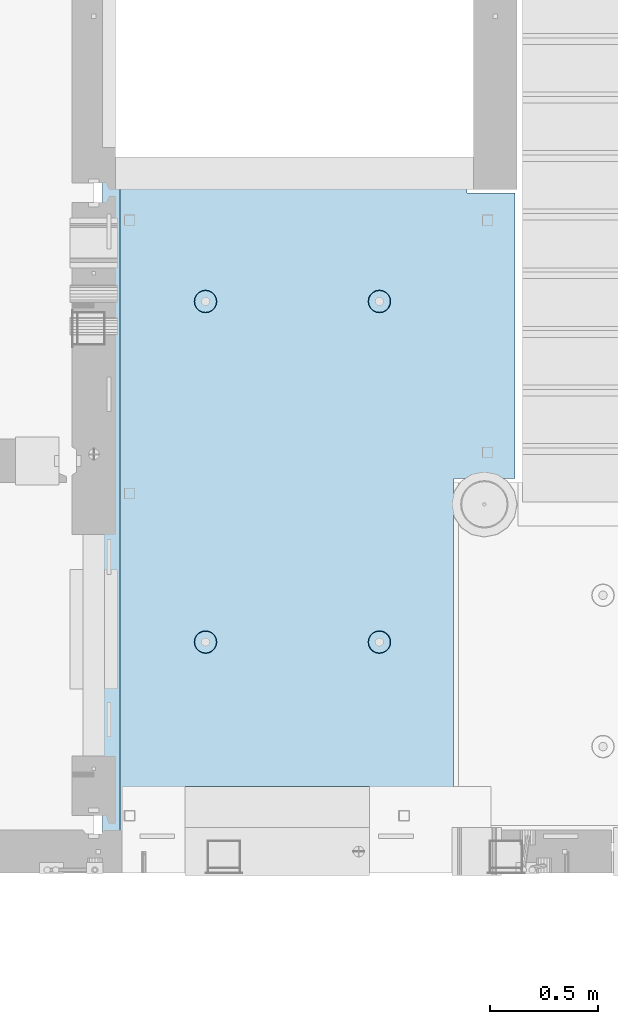
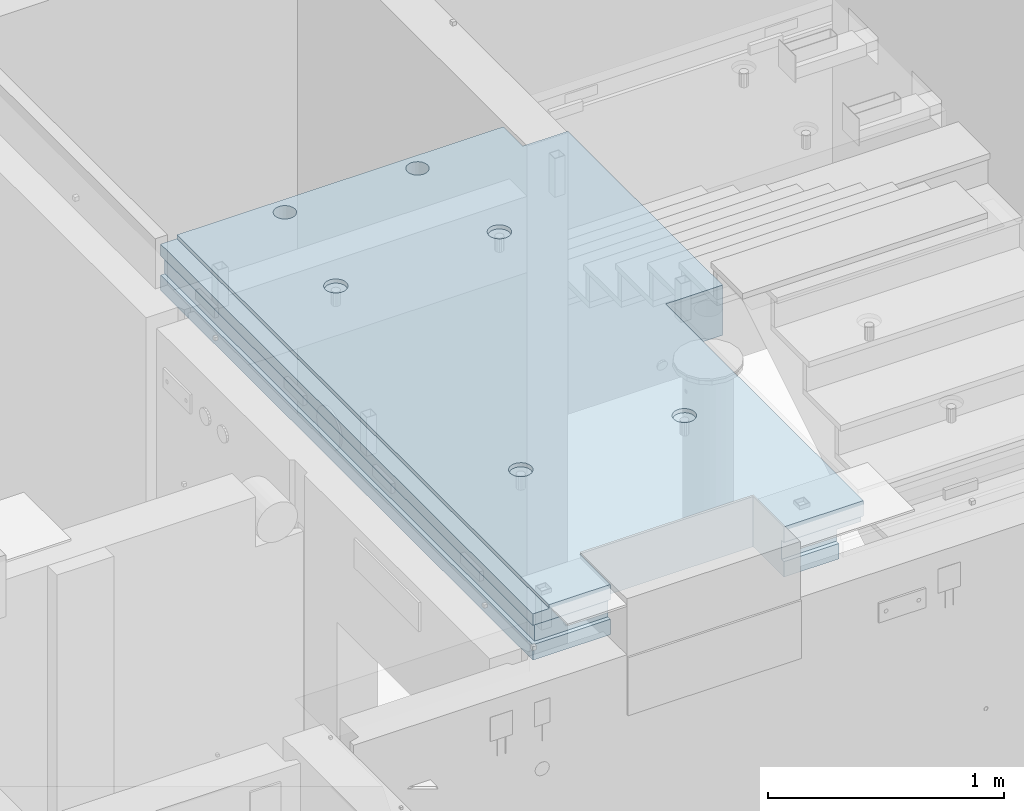
# One storey, part 148 of 264: 1 slab, 1 element without a shape of its own.
"""IFC2X3 building model written with IfcOpenShell, lengths in millimetres."""

import ifcopenshell
import ifcopenshell.guid

model = None  # the IFC model being written
_history = None  # IfcOwnerHistory: only IFC2X3 demands one
_inside = {}  # id of a spatial element -> (the spatial element, [elements in it])
_under = {}  # id of a project, library or spatial element -> (it, [spatial elements below it])
_declared = {}  # id of a project -> (the project, [libraries it declares])
_typed = {}  # id of a type object -> (the type object, [elements of that type])
_made_of = {}  # id of a material, layer set ... -> (it, [elements and type objects made of it])


def new_model(schema):
    """Start an empty IFC model of exactly this schema.

    Asked for "IFC4X3", IfcOpenShell would pick the latest addendum, in which some entities
    have other attributes; the version numbers below select the first issue.
    IFC2X3 requires an IfcOwnerHistory on every rooted entity: one is made here for all.
    """
    global model, _history
    if schema == "IFC4X3":
        model = ifcopenshell.file(schema_version=(4, 3, 0, 0))
    else:
        model = ifcopenshell.file(schema=schema)
    _inside.clear()
    _under.clear()
    _declared.clear()
    _typed.clear()
    _made_of.clear()
    _history = None
    if model.schema == "IFC2X3":
        org = make("IfcOrganization", Name="unknown")
        user = make(
            "IfcPersonAndOrganization",
            ThePerson=make("IfcPerson", FamilyName="unknown"),
            TheOrganization=org,
        )
        app = make(
            "IfcApplication",
            ApplicationDeveloper=org,
            Version="unknown",
            ApplicationFullName="unknown",
            ApplicationIdentifier="unknown",
        )
        _history = make(
            "IfcOwnerHistory",
            OwningUser=user,
            OwningApplication=app,
            ChangeAction="ADDED",
            CreationDate=0,
        )
    return model


def make(cls, **values):
    """One entity of the class cls with the attributes given. An attribute that is None is left unset."""
    return model.create_entity(
        cls, **{name: value for name, value in values.items() if value is not None}
    )


def rooted(cls, **values):
    """An entity with a GlobalId (a new one), such as an element, a storey or a relation."""
    return make(cls, GlobalId=ifcopenshell.guid.new(), OwnerHistory=_history, **values)


def si_unit(unit_type, name, prefix=None):
    """IfcSIUnit, for example si_unit("LENGTHUNIT", "METRE", prefix="MILLI")."""
    return make("IfcSIUnit", UnitType=unit_type, Prefix=prefix, Name=name)


def assignment(units):
    """IfcUnitAssignment: the units of a project."""
    return None if units is None else make("IfcUnitAssignment", Units=units)


def point(xyz):
    """IfcCartesianPoint."""
    return None if xyz is None else make("IfcCartesianPoint", Coordinates=xyz)


def direction(xyz):
    """IfcDirection."""
    return None if xyz is None else make("IfcDirection", DirectionRatios=xyz)


def frame(location, z_axis=None, x_axis=None):
    """IfcAxis2Placement3D, a coordinate frame: its origin and axes. An axis left out is left unset."""
    return make(
        "IfcAxis2Placement3D",
        Location=point(location),
        Axis=direction(z_axis),
        RefDirection=direction(x_axis),
    )


def origin_with_axes():
    """The frame at (0, 0, 0) with the z axis (0, 0, 1) and the x axis (1, 0, 0) written out."""
    return frame((0.0, 0.0, 0.0), z_axis=(0.0, 0.0, 1.0), x_axis=(1.0, 0.0, 0.0))


def place(relative_to, where):
    """IfcLocalPlacement: puts the frame where relative to a parent placement (None: the world)."""
    return make(
        "IfcLocalPlacement", PlacementRelTo=relative_to, RelativePlacement=where
    )


def context(
    kind, dimensions, precision=None, world=None, true_north=None, identifier=None
):
    """IfcGeometricRepresentationContext, for example the 3D "Model" context."""
    return make(
        "IfcGeometricRepresentationContext",
        ContextIdentifier=identifier,
        ContextType=kind,
        CoordinateSpaceDimension=dimensions,
        Precision=precision,
        WorldCoordinateSystem=world,
        TrueNorth=true_north,
    )


def subcontext(parent, identifier, kind, view, scale=None):
    """IfcGeometricRepresentationSubContext, for example "Body" below "Model"."""
    return make(
        "IfcGeometricRepresentationSubContext",
        ContextIdentifier=identifier,
        ContextType=kind,
        ParentContext=parent,
        TargetScale=scale,
        TargetView=view,
    )


def project(units=None, contexts=None):
    """IfcProject with its units and contexts."""
    return rooted(
        "IfcProject",
        Name="project",
        RepresentationContexts=contexts,
        UnitsInContext=assignment(units),
    )


def spatial(cls, under=None, at=None, **own):
    """A site, building, storey or space (cls), placed at a placement, below another one or the project."""
    s = rooted(cls, ObjectPlacement=at, **own)
    if under is not None:
        _under.setdefault(under.id(), (under, []))[1].append(s)
    return s


def faces_of(points, faces, orient=None, outer=None):
    """IfcFace entities. A face is a list of loops; a loop is a list of indices into points, from 0.

    orient and outer hold one flag for each loop. By default every Orientation is true, the
    first loop of a face is its IfcFaceOuterBound and the others are IfcFaceBound.
    """
    made = []
    for i, loops in enumerate(faces):
        bounds = []
        for j, loop in enumerate(loops):
            is_outer = j == 0 if outer is None else outer[i][j]
            bounds.append(
                make(
                    "IfcFaceOuterBound" if is_outer else "IfcFaceBound",
                    Bound=make("IfcPolyLoop", Polygon=[points[k] for k in loop]),
                    Orientation=True if orient is None else orient[i][j],
                )
            )
        made.append(make("IfcFace", Bounds=bounds))
    return made


def faceted_brep(points, faces, orient=None, outer=None, voids=None):
    """IfcFacetedBrep: a solid bounded by flat faces; with voids (closed shells), ...WithVoids."""
    shared = [point(p) for p in points]
    hull = make("IfcClosedShell", CfsFaces=faces_of(shared, faces, orient, outer))
    if voids is None:
        return make("IfcFacetedBrep", Outer=hull)
    return make(
        "IfcFacetedBrepWithVoids",
        Outer=hull,
        Voids=[
            make(cls, CfsFaces=faces_of(shared, fs, o, b)) for cls, fs, o, b in voids
        ],
    )


def shape(context_of_items, identifier, shape_type, items):
    """IfcShapeRepresentation: the items that make up one representation, for example the "Body"."""
    return make(
        "IfcShapeRepresentation",
        ContextOfItems=context_of_items,
        RepresentationIdentifier=identifier,
        RepresentationType=shape_type,
        Items=items,
    )


def material(Name=None, Category=None):
    """IfcMaterial."""
    return make("IfcMaterial", Name=Name, Category=Category)


def made_of(thing, what):
    """Note that an element or type object is made of a material, layer set ...; save() writes the relation."""
    if what is not None:
        _made_of.setdefault(what.id(), (what, []))[1].append(thing)
    return thing


def type_object(cls, material=None, **own):
    """A type object (cls), such as IfcWallType, which elements share."""
    return made_of(rooted(cls, **own), material)


def element(
    cls,
    number,
    at=None,
    inside=None,
    cuts=None,
    type_object=None,
    material=None,
    context=None,
    identifier="Body",
    shape_type=None,
    held_by="IfcProductDefinitionShape",
    body=None,
    shapes=None,
    **own,
):
    """One element of the class cls, such as IfcWall. Its Tag is "e" and its number.

    at: its placement. inside: the storey or other place that contains it. cuts: it is an
    opening in that element (IfcRelVoidsElement). A single representation is given by context,
    identifier, shape_type and body (its items); several are given by shapes. held_by: the class
    of the entity that holds the representations. save() writes the other relations.
    """
    e = rooted(cls, Tag="e%d" % number, ObjectPlacement=at, **own)
    if body is not None:
        shapes = [shape(context, identifier, shape_type, body)]
    if shapes is not None:
        e.Representation = make(held_by, Representations=shapes)
    if inside is not None:
        _inside.setdefault(inside.id(), (inside, []))[1].append(e)
    if cuts is not None:
        rooted(
            "IfcRelVoidsElement", RelatingBuildingElement=cuts, RelatedOpeningElement=e
        )
    if type_object is not None:
        _typed.setdefault(type_object.id(), (type_object, []))[1].append(e)
    return made_of(e, material)


def aggregate(whole, parts):
    """IfcRelAggregates: a whole, such as a stair, and the parts it consists of."""
    return rooted("IfcRelAggregates", RelatingObject=whole, RelatedObjects=parts)


def save(model, path):
    """Write the relations noted so far, then the file.

    IfcRelAggregates (storeys below a building ...), IfcRelContainedInSpatialStructure (elements
    in a storey), IfcRelDefinesByType, IfcRelAssociatesMaterial and IfcRelDeclares: one each for
    every whole, place, type object, material and project.
    """
    for whole, parts in _under.values():
        aggregate(whole, parts)
    for where, things in _inside.values():
        rooted(
            "IfcRelContainedInSpatialStructure",
            RelatedElements=things,
            RelatingStructure=where,
        )
    for kind, things in _typed.values():
        rooted("IfcRelDefinesByType", RelatedObjects=things, RelatingType=kind)
    for what, things in _made_of.values():
        rooted("IfcRelAssociatesMaterial", RelatedObjects=things, RelatingMaterial=what)
    for by, libraries in _declared.values():
        rooted("IfcRelDeclares", RelatingContext=by, RelatedDefinitions=libraries)
    model.write(path)


model = new_model("IFC2X3")

# Units and contexts
model_context = context("Model", 3, precision=1e-05, world=origin_with_axes())
body_context = subcontext(model_context, "Body", "Model", "MODEL_VIEW")
ifc_project = project(units=[si_unit("LENGTHUNIT", "METRE", prefix="MILLI"), si_unit("AREAUNIT", "SQUARE_METRE"), si_unit("VOLUMEUNIT", "CUBIC_METRE"), si_unit("MASSUNIT", "GRAM", prefix="KILO"), si_unit("TIMEUNIT", "SECOND"), si_unit("PLANEANGLEUNIT", "RADIAN"), si_unit("SOLIDANGLEUNIT", "STERADIAN"), si_unit("THERMODYNAMICTEMPERATUREUNIT", "DEGREE_CELSIUS"), si_unit("LUMINOUSINTENSITYUNIT", "LUMEN")], contexts=[model_context])

# Site, building, storey
site_placement = place(None, origin_with_axes())
site = spatial("IfcSite", under=ifc_project, at=site_placement, CompositionType="ELEMENT")
building_placement = place(site_placement, origin_with_axes())
building = spatial("IfcBuilding", under=site, at=building_placement, CompositionType="ELEMENT")
storey_placement = place(building_placement, origin_with_axes())
storey = spatial("IfcBuildingStorey", under=building, at=storey_placement, Name="K", CompositionType="ELEMENT", Elevation=0.0)

# Assembly, slab
assembly_placement = place(storey_placement, origin_with_axes())
assembly = element("IfcElementAssembly", 1, at=assembly_placement, inside=storey, AssemblyPlace="NOTDEFINED", PredefinedType="REINFORCEMENT_UNIT")
ifc_material = material(Name="CONCRETE/C25/30")
slab_type = type_object("IfcSlabType", PredefinedType="NOTDEFINED")
slab_placement = place(assembly_placement, frame((19370.0122708302, 15219.9992031236, 81620.0), z_axis=(-0.999999999999509, -9.91000000794397e-07, 0.0), x_axis=(0.0, 1.0, 0.0)))
slab = element("IfcSlab", 2, at=slab_placement, type_object=slab_type, material=ifc_material, PredefinedType="FLOOR", context=body_context, shape_type="Brep", body=[
    faceted_brep([(3059.54583934266, -130.0, 1012.45761780167), (3059.54583934266, 130.000000000015, 1012.45761780167), (3045.60743348485, 130.000000000015, 1019.55960771063), (3045.60743348485, -130.0, 1019.55960771063), (3034.54585734276, 130.000000000015, 1030.62120577679), (3034.54585734276, -130.0, 1030.62120577679), (3027.44389505973, 130.000000000015, 1044.55962571071), (3027.44389505973, -130.0, 1044.55962571071), (3024.99673618627, 130.000000000015, 1060.0104778546), (3024.99673618627, -130.0, 1060.0104778546), (3027.44392568331, 130.000000000015, 1075.4613251482), (3027.44392568331, -130.0, 1075.4613251482), (3034.54591559228, 130.000000000015, 1089.39973100601), (3034.54591559228, -130.0, 1089.39973100601), (3045.60751365843, 130.000000000015, 1100.46130714809), (3045.60751365843, -130.0, 1100.46130714809), (3059.54593359236, 130.000000000015, 1107.56326943113), (3059.54593359236, -130.0, 1107.56326943113), (3074.99678573625, 130.000000000015, 1110.01042830458), (3074.99678573625, -130.0, 1110.01042830458), (3090.44763302984, 130.000000000015, 1107.56323880755), (3090.44763302984, -130.0, 1107.56323880755), (3104.38603888765, 130.000000000015, 1100.46124889857), (3104.38603888765, -130.0, 1100.46124889857), (3115.44761502974, 130.000000000015, 1089.39965083242), (3115.44761502974, -130.0, 1089.39965083242), (3122.54957731278, 130.000000000015, 1075.4612308985), (3122.54957731278, -130.0, 1075.4612308985), (3124.99673618622, 130.000000000015, 1060.01037875461), (3124.99673618622, -130.0, 1060.01037875461), (3122.54954668919, 130.000000000015, 1044.55953146101), (3122.54954668919, -130.0, 1044.55953146101), (3115.44755678022, 130.000000000015, 1030.62112560321), (3115.44755678022, -130.0, 1030.62112560321), (3104.38595871407, 130.000000000015, 1019.55954946112), (3104.38595871407, -130.0, 1019.55954946112), (3090.44753878014, 130.000000000015, 1012.45758717808), (3090.44753878014, -130.0, 1012.45758717808), (3074.99668663625, 130.000000000015, 1010.01042830463), (3074.99668663625, -130.0, 1010.01042830463), (3159.99514031089, -49.9988649334991, 1600.01649516996), (3159.99514031089, 50.0011350665009, 1600.01649516997), (20.0049787505723, 50.0007865275984, 1600.01633503047), (20.0049787505723, -49.9992134724016, 1600.01633503046), (3159.9951171875, 50.0011350665009, 1620.01159667969), (20.0049456267261, 50.0007865278894, 1620.0117179773), (0.00240110606137023, 50.0007843076019, 1620.01171875), (0.00502548625809141, 50.0007843076019, 1600.01633401047), (3159.9951171875, 130.0, 1620.01159667969), (0.00240110606137023, 130.0, 1620.01171875), (260.005683103422, -130.0, 1240.0121672432), (260.005683103422, 130.000000000015, 1240.0121672432), (260.004840753232, 130.0, 390.011976508747), (260.004840753232, -130.0, 390.011976508747), (0.00183788849062694, 50.0011356208415, 1240.01223417214), (0.00183788849062694, 130.0, 1240.01223417214), (0.00183788848880795, -130.0, 1240.01223417214), (0.00183788848880795, -49.9988643791585, 1240.01223417214), (20.0055756373404, -49.9988643791585, 1240.01222902288), (20.0055756373404, 50.0011356208415, 1240.01222902288), (0.00503658625711978, -49.9992156923981, 1600.01633401046), (0.00228253377099463, -130.0, 1540.01171275863), (-0.000325276030707755, -109.999999999985, 1540.0117127625), (0.00240110606137023, -109.999999999985, 1620.01171875), (0.00240110606137023, -49.9992156923981, 1620.01171875), (3159.99520970311, -129.999999999985, 1540.01211092194), (3159.99520970311, -109.999999999985, 1540.01211092194), (3159.9951171875, -109.999999999985, 1620.01159667969), (3159.9951171875, -49.9988649334991, 1620.01159667969), (20.0049456267261, -49.9992134721106, 1620.0117179773), (3159.99706003359, -130.0, -59.9935364350204), (3159.99706003359, 130.0, -59.9935364350204), (2994.99759043856, -130.0, -59.9933729204568), (2994.99759043856, 130.0, -59.9933729204568), (2994.99737241856, -130.0, -279.993372920348), (2994.99737241857, 130.0, -279.993537078055), (1680.00305175781, -130.0, -279.99359130859), (1680.00305175781, 130.0, -279.99359130859), (20.0074326181893, 50.0011356208415, 119.999652715691), (20.0069849373631, 50.0011356208415, 390.012214346807), (0.000578058003156912, 50.0011356208415, 390.012234173173), (0.00292781145253684, 50.0011354659946, 119.999647654306), (0.000578058003156912, 130.0, 390.012234173173), (0.000177857900780509, 130.0, 119.99964765838), (1680.00499034921, 129.999999999942, 120.000072691248), (1680.00499034921, -10.0000000000582, 120.000072691248), (20.0074326181912, -10.0000000000582, 119.999652711864), (1680.00502070923, -10.0000000000582, 1.53886503539979e-09), (1680.00354003906, 130.0, 1.16779119707644e-09), (1680.00354003906, -130.0, 1.16779119707644e-09), (1680.00350516116, 130.0, -19.999927306093), (0.0, -130.0, -3.63797880709171e-12), (0.000578058003156912, -130.0, 390.012234173173), (0.000578058003156912, -49.9988643791585, 390.012234173173), (1.81898940354586e-12, -49.9988643791585, 0.0), (20.0076315948209, -49.9988643791585, -0.0103771893882367), (20.0076315948209, -10.0000000000582, 1.81898940354586e-11), (20.0069849373631, -49.9988643791585, 390.012214346807), (2510.44873202231, -110.0, 1097.45764722809), (2524.38715195623, -110.0, 1104.55960951113), (2535.44875002239, -110.0, 1115.62118565321), (2542.55073993136, -110.0, 1129.55959151102), (2544.9979294284, -110.0, 1145.01043880461), (2542.55077055495, -110.0, 1160.4612909485), (2535.44880827191, -110.0, 1174.39971088243), (2524.38723212982, -110.0, 1185.46130894859), (2510.44882627201, -110.0, 1192.56329885756), (2494.99797897842, -110.0, 1195.01048835459), (2479.54712683453, -110.0, 1192.56332948114), (2465.6087069006, -110.0, 1185.4613671981), (2454.54710883445, -110.0, 1174.39979105601), (2447.44511892548, -110.0, 1160.46138519821), (2444.99792942845, -110.0, 1145.01053790461), (2447.44508830189, -110.0, 1129.55968576073), (2454.54705058493, -110.0, 1115.6212658268), (2465.60862672702, -110.0, 1104.55966776064), (2479.54703258483, -110.0, 1097.45767785167), (2494.99787987842, -110.0, 1095.01048835464), (2511.15104123112, -130.0, 1095.29615444961), (2494.99787762615, -130.0, 1092.73776108191), (2525.7230257075, -130.0, 1102.72093320006), (2537.28742368575, -130.0, 1114.28530825769), (2544.71223131786, -130.0, 1128.85727801813), (2547.27065670112, -130.0, 1145.01043655234), (2544.71226333343, -130.0, 1161.16360015732), (2537.28748458297, -130.0, 1175.73558463369), (2525.72310952534, -130.0, 1187.29998261194), (2511.1511397649, -130.0, 1194.72479024406), (2494.99798123069, -130.0, 1197.28321562731), (2478.84481762572, -130.0, 1194.72482225962), (2464.27283314934, -130.0, 1187.30004350917), (2452.70843517109, -130.0, 1175.73566845153), (2445.28362753898, -130.0, 1161.1636986911), (2442.72520215572, -130.0, 1145.01054015689), (2445.28359552342, -130.0, 1128.85737655191), (2452.70837427387, -130.0, 1114.28539207553), (2464.2727493315, -130.0, 1102.72099409729), (2478.84471909194, -130.0, 1095.29618646517), (2510.4488978321, -110.0, 296.159014079574), (2524.38731776602, -110.0, 303.26097636261), (2535.44891583217, -110.0, 314.322552504698), (2542.55090574115, -110.0, 328.260958362509), (2544.99809523818, -110.0, 343.711805656101), (2542.55093636473, -110.0, 359.162657799989), (2535.44897408169, -110.0, 373.101077733914), (2524.3873979396, -110.0, 384.162675800068), (2510.44899208179, -110.0, 391.264665709041), (2494.9981447882, -110.0, 393.711855206075), (2479.54729264431, -110.0, 391.264696332622), (2465.60887271039, -110.0, 384.162734049587), (2454.54727464424, -110.0, 373.101157907498), (2447.44528473526, -110.0, 359.162752049688), (2444.99809523823, -110.0, 343.711904756099), (2447.44525411168, -110.0, 328.261052612208), (2454.54721639472, -110.0, 314.322632678282), (2465.6087925368, -110.0, 303.261034612129), (2479.54719839461, -110.0, 296.159044703156), (2494.9980456882, -110.0, 293.711855206122), (2511.15120704091, -130.0, 293.997521301091), (2494.99804343593, -130.0, 291.439127933398), (2525.72319151729, -130.0, 301.422300051545), (2537.28758949553, -130.0, 312.986675109179), (2544.71239712765, -130.0, 327.558644869619), (2547.27082251091, -130.0, 343.711803403829), (2544.71242914321, -130.0, 359.864967008802), (2537.28765039276, -130.0, 374.436951485179), (2525.72327533512, -130.0, 386.001349463426), (2511.15130557468, -130.0, 393.426157095539), (2494.99814704047, -130.0, 395.984582478803), (2478.8449834355, -130.0, 393.426189111105), (2464.27299895912, -130.0, 386.001410360652), (2452.70860098088, -130.0, 374.437035303017), (2445.28379334876, -130.0, 359.865065542577), (2442.7253679655, -130.0, 343.711907008372), (2445.2837613332, -130.0, 327.558743403395), (2452.70854008365, -130.0, 312.986758927018), (2464.27291514129, -130.0, 301.422360948771), (2478.84488490173, -130.0, 293.997553316658), (909.695131144432, -110.0, 1192.56488520447), (895.756711210501, -110.0, 1185.46292292143), (884.695113144351, -110.0, 1174.40134677934), (877.593123235378, -110.0, 1160.46294092153), (875.145933738344, -110.0, 1145.01209362794), (877.593092611794, -110.0, 1129.56124148405), (884.695054894833, -110.0, 1115.62282155013), (895.756631036917, -110.0, 1104.56122348397), (909.695036894731, -110.0, 1097.459233575), (925.14588418832, -110.0, 1095.01204407796), (940.596736332209, -110.0, 1097.45920295142), (954.535156266138, -110.0, 1104.56116523445), (965.596754332289, -110.0, 1115.62274137654), (972.698744241263, -110.0, 1129.56114723435), (975.145933738295, -110.0, 1145.01199452794), (972.698774864846, -110.0, 1160.46284667183), (965.596812581807, -110.0, 1174.40126660576), (954.535236439722, -110.0, 1185.46286467191), (940.59683058191, -110.0, 1192.56485458088), (925.145983288319, -110.0, 1195.01204407792), (941.299045541024, -130.000000000015, 1095.29771017294), (925.145881936047, -130.000000000015, 1092.73931680524), (955.871030017401, -130.000000000015, 1102.72248892339), (967.435427995651, -130.000000000015, 1114.28686398102), (974.860235627762, -130.000000000015, 1128.85883374146), (977.418661011023, -130.000000000015, 1145.01199227567), (974.860267643326, -130.0, 1161.16515588064), (967.435488892876, -130.0, 1175.73714035702), (955.871113835239, -130.0, 1187.30153833527), (941.299144074801, -130.000000000015, 1194.72634596739), (925.145985540592, -130.000000000015, 1197.28477135064), (908.992821935617, -130.000000000015, 1194.72637798295), (894.420837459238, -130.000000000015, 1187.3015992325), (882.856439480989, -130.000000000015, 1175.73722417486), (875.431631848878, -130.000000000015, 1161.16525441442), (872.873206465616, -130.000000000015, 1145.01209588021), (875.431599833313, -130.000000000015, 1128.85893227524), (882.856378583765, -130.000000000015, 1114.28694779886), (894.4207536414, -130.000000000015, 1102.72254982061), (908.99272340184, -130.000000000015, 1095.2977421885), (909.693377160755, -110.0, 391.266252057852), (895.754957226825, -110.0, 384.164289774817), (884.693359160676, -110.0, 373.102713632728), (877.591369251702, -110.0, 359.164307774918), (875.144179754669, -110.0, 343.713460481329), (877.591338628117, -110.0, 328.262608337438), (884.693300911156, -110.0, 314.324188403512), (895.754877053241, -110.0, 303.262590337359), (909.693282911054, -110.0, 296.160600428386), (925.144130204642, -110.0, 293.713410931352), (940.594982348532, -110.0, 296.160569804801), (954.533402282463, -110.0, 303.26253208784), (965.595000348612, -110.0, 314.324108229928), (972.696990257586, -110.0, 328.262514087739), (975.144179754619, -110.0, 343.713361381331), (972.697020881171, -110.0, 359.164213525219), (965.595058598132, -110.0, 373.102633459144), (954.533482456047, -110.0, 384.164231525298), (940.595076598232, -110.0, 391.266221434267), (925.144229304644, -110.0, 393.713410931305), (941.297291557346, -130.000000000015, 293.999077026321), (925.14412795237, -130.000000000015, 291.440683658628), (955.869276033725, -130.000000000015, 301.423855776771), (967.433674011974, -130.000000000015, 312.988230834409), (974.858481644085, -130.000000000015, 327.560200594846), (977.416907027347, -130.000000000015, 343.713359129059), (974.85851365965, -130.000000000015, 359.866522734028), (967.433734909198, -130.000000000015, 374.438507210409), (955.869359851564, -130.000000000015, 386.00290518866), (941.297390091126, -130.000000000015, 393.427712820769), (925.144231556917, -130.000000000015, 395.986138204033), (908.991067951942, -130.000000000015, 393.427744836335), (894.419083475563, -130.000000000015, 386.002966085885), (882.854685497312, -130.000000000015, 374.438591028247), (875.429877865201, -130.000000000015, 359.866621267807), (872.871452481941, -130.000000000015, 343.713462733602), (875.429845849636, -130.000000000015, 327.560299128625), (882.854624600088, -130.000000000015, 312.988314652248), (894.418999657724, -130.000000000015, 301.423916673997), (908.990969418162, -130.000000000015, 293.999109041888), (3045.60678933485, -130.0, 369.559607710955), (3034.54521319276, -130.0, 380.621205777112), (3027.44325090972, -130.0, 394.559625711034), (3024.99609203627, -130.0, 410.010477854925), (3027.44328153331, -130.0, 425.461325148517), (3034.54527144228, -130.0, 439.399731006328), (3045.60686950843, -130.0, 450.461307148413), (3059.54528944236, -130.0, 457.563269431452), (3074.99614158625, -130.0, 460.0104283049), (3090.44698887984, -130.0, 457.563238807867), (3104.38539473765, -130.0, 450.461248898893), (3115.44697087974, -130.0, 439.399650832744), (3122.54893316278, -130.0, 425.461230898818), (3124.99609203622, -130.0, 410.010378754927), (3122.54890253919, -130.0, 394.559531461335), (3115.44691263022, -130.0, 380.621125603528), (3104.38531456406, -130.0, 369.559549461435), (3090.44689463014, -130.0, 362.4575871784), (3074.99604248625, -130.0, 360.010428304948), (3059.54519519266, -130.0, 362.457617801985), (3104.38531456406, 130.000000000015, 369.559549461435), (3090.44689463014, 130.000000000015, 362.4575871784), (3115.44691263022, 130.000000000015, 380.621125603528), (3122.54890253919, 130.000000000015, 394.559531461335), (3124.99609203622, 130.000000000015, 410.010378754927), (3122.54893316278, 130.000000000015, 425.461230898818), (3115.44697087974, 130.000000000015, 439.399650832744), (3104.38539473765, 130.000000000015, 450.461248898893), (3090.44698887984, 130.000000000015, 457.563238807867), (3074.99614158625, 130.000000000015, 460.0104283049), (3059.54528944236, 130.000000000015, 457.563269431452), (3045.60686950843, 130.000000000015, 450.461307148413), (3034.54527144228, 130.000000000015, 439.399731006328), (3027.44328153331, 130.000000000015, 425.461325148517), (3024.99609203627, 130.000000000015, 410.010477854925), (3027.44325090972, 130.000000000015, 394.559625711034), (3034.54521319276, 130.000000000015, 380.621205777112), (3045.60678933485, 130.000000000015, 369.559607710955), (3059.54519519266, 130.000000000015, 362.457617801985), (3074.99604248625, 130.000000000015, 360.010428304948)], [[[0, 1, 2, 3]], [[3, 2, 4, 5]], [[5, 4, 6, 7]], [[7, 6, 8, 9]], [[9, 8, 10, 11]], [[11, 10, 12, 13]], [[13, 12, 14, 15]], [[15, 14, 16, 17]], [[17, 16, 18, 19]], [[19, 18, 20, 21]], [[21, 20, 22, 23]], [[23, 22, 24, 25]], [[25, 24, 26, 27]], [[27, 26, 28, 29]], [[29, 28, 30, 31]], [[31, 30, 32, 33]], [[33, 32, 34, 35]], [[35, 34, 36, 37]], [[37, 36, 38, 39]], [[39, 38, 1, 0]], [[40, 41, 42, 43]], [[44, 45, 46, 47, 42, 41]], [[44, 48, 49, 46, 45]], [[50, 51, 52, 53]], [[54, 55, 51, 50, 56, 57, 58, 59]], [[46, 49, 55, 54, 47]], [[59, 42, 47, 54]], [[58, 43, 42, 59]], [[57, 60, 43, 58]], [[56, 61, 62, 63, 64, 60, 57]], [[65, 66, 62, 61]], [[67, 63, 62, 66]], [[64, 63, 67, 68, 69]], [[40, 43, 60, 64, 69, 68]], [[67, 66, 65, 70, 71, 48, 44, 41, 40, 68]], [[70, 72, 73, 71]], [[74, 75, 73, 72]], [[76, 77, 75, 74]], [[78, 79, 80, 81]], [[82, 83, 81, 80]], [[81, 83, 84, 85, 86, 78]], [[87, 85, 84, 88]], [[76, 89, 87, 88, 90, 77]], [[91, 92, 93, 94]], [[87, 89, 91, 94, 95, 96]], [[85, 87, 96, 86]], [[95, 97, 79, 78, 86, 96]], [[94, 93, 97, 95]], [[92, 53, 52, 82, 80, 79, 97, 93]], [[98, 99, 100, 101, 102, 103, 104, 105, 106, 107, 108, 109, 110, 111, 112, 113, 114, 115, 116, 117]], [[118, 98, 117, 119]], [[120, 99, 98, 118]], [[121, 100, 99, 120]], [[122, 101, 100, 121]], [[123, 102, 101, 122]], [[124, 103, 102, 123]], [[125, 104, 103, 124]], [[126, 105, 104, 125]], [[127, 106, 105, 126]], [[128, 107, 106, 127]], [[129, 108, 107, 128]], [[130, 109, 108, 129]], [[131, 110, 109, 130]], [[132, 111, 110, 131]], [[133, 112, 111, 132]], [[134, 113, 112, 133]], [[135, 114, 113, 134]], [[136, 115, 114, 135]], [[137, 116, 115, 136]], [[119, 117, 116, 137]], [[138, 139, 140, 141, 142, 143, 144, 145, 146, 147, 148, 149, 150, 151, 152, 153, 154, 155, 156, 157]], [[158, 138, 157, 159]], [[160, 139, 138, 158]], [[161, 140, 139, 160]], [[162, 141, 140, 161]], [[163, 142, 141, 162]], [[164, 143, 142, 163]], [[165, 144, 143, 164]], [[166, 145, 144, 165]], [[167, 146, 145, 166]], [[168, 147, 146, 167]], [[169, 148, 147, 168]], [[170, 149, 148, 169]], [[171, 150, 149, 170]], [[172, 151, 150, 171]], [[173, 152, 151, 172]], [[174, 153, 152, 173]], [[175, 154, 153, 174]], [[176, 155, 154, 175]], [[177, 156, 155, 176]], [[159, 157, 156, 177]], [[178, 179, 180, 181, 182, 183, 184, 185, 186, 187, 188, 189, 190, 191, 192, 193, 194, 195, 196, 197]], [[198, 188, 187, 199]], [[200, 189, 188, 198]], [[201, 190, 189, 200]], [[202, 191, 190, 201]], [[203, 192, 191, 202]], [[204, 193, 192, 203]], [[205, 194, 193, 204]], [[206, 195, 194, 205]], [[207, 196, 195, 206]], [[208, 197, 196, 207]], [[209, 178, 197, 208]], [[210, 179, 178, 209]], [[211, 180, 179, 210]], [[212, 181, 180, 211]], [[213, 182, 181, 212]], [[214, 183, 182, 213]], [[215, 184, 183, 214]], [[216, 185, 184, 215]], [[217, 186, 185, 216]], [[199, 187, 186, 217]], [[218, 219, 220, 221, 222, 223, 224, 225, 226, 227, 228, 229, 230, 231, 232, 233, 234, 235, 236, 237]], [[238, 228, 227, 239]], [[240, 229, 228, 238]], [[241, 230, 229, 240]], [[242, 231, 230, 241]], [[243, 232, 231, 242]], [[244, 233, 232, 243]], [[245, 234, 233, 244]], [[246, 235, 234, 245]], [[247, 236, 235, 246]], [[248, 237, 236, 247]], [[249, 218, 237, 248]], [[250, 219, 218, 249]], [[251, 220, 219, 250]], [[252, 221, 220, 251]], [[253, 222, 221, 252]], [[254, 223, 222, 253]], [[255, 224, 223, 254]], [[256, 225, 224, 255]], [[257, 226, 225, 256]], [[239, 227, 226, 257]], [[91, 89, 76, 74, 72, 70, 65, 61, 56, 50, 53, 92], [3, 5, 7, 9, 11, 13, 15, 17, 19, 21, 23, 25, 27, 29, 31, 33, 35, 37, 39, 0], [258, 259, 260, 261, 262, 263, 264, 265, 266, 267, 268, 269, 270, 271, 272, 273, 274, 275, 276, 277], [256, 255, 254, 253, 252, 251, 250, 249, 248, 247, 246, 245, 244, 243, 242, 241, 240, 238, 239, 257], [216, 215, 214, 213, 212, 211, 210, 209, 208, 207, 206, 205, 204, 203, 202, 201, 200, 198, 199, 217], [176, 175, 174, 173, 172, 171, 170, 169, 168, 167, 166, 165, 164, 163, 162, 161, 160, 158, 159, 177], [136, 135, 134, 133, 132, 131, 130, 129, 128, 127, 126, 125, 124, 123, 122, 121, 120, 118, 119, 137]], [[274, 278, 279, 275]], [[273, 280, 278, 274]], [[272, 281, 280, 273]], [[271, 282, 281, 272]], [[270, 283, 282, 271]], [[269, 284, 283, 270]], [[268, 285, 284, 269]], [[267, 286, 285, 268]], [[266, 287, 286, 267]], [[265, 288, 287, 266]], [[264, 289, 288, 265]], [[263, 290, 289, 264]], [[262, 291, 290, 263]], [[261, 292, 291, 262]], [[260, 293, 292, 261]], [[259, 294, 293, 260]], [[258, 295, 294, 259]], [[277, 296, 295, 258]], [[276, 297, 296, 277]], [[275, 279, 297, 276]], [[55, 49, 48, 71, 73, 75, 77, 90, 88, 84, 83, 82, 52, 51], [34, 32, 30, 28, 26, 24, 22, 20, 18, 16, 14, 12, 10, 8, 6, 4, 2, 1, 38, 36], [278, 280, 281, 282, 283, 284, 285, 286, 287, 288, 289, 290, 291, 292, 293, 294, 295, 296, 297, 279]]]),
])
aggregate(assembly, [slab])

save(model, "model.ifc")
